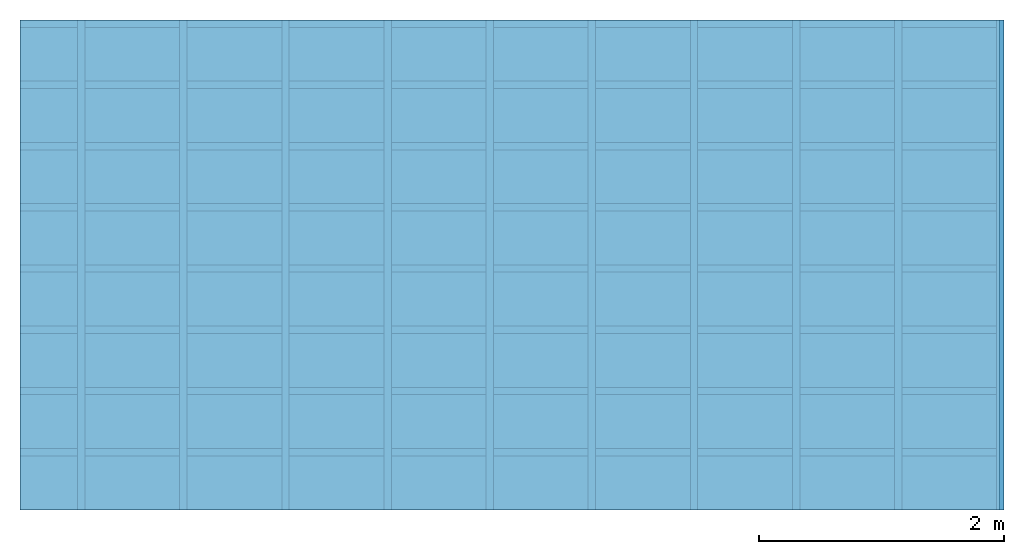
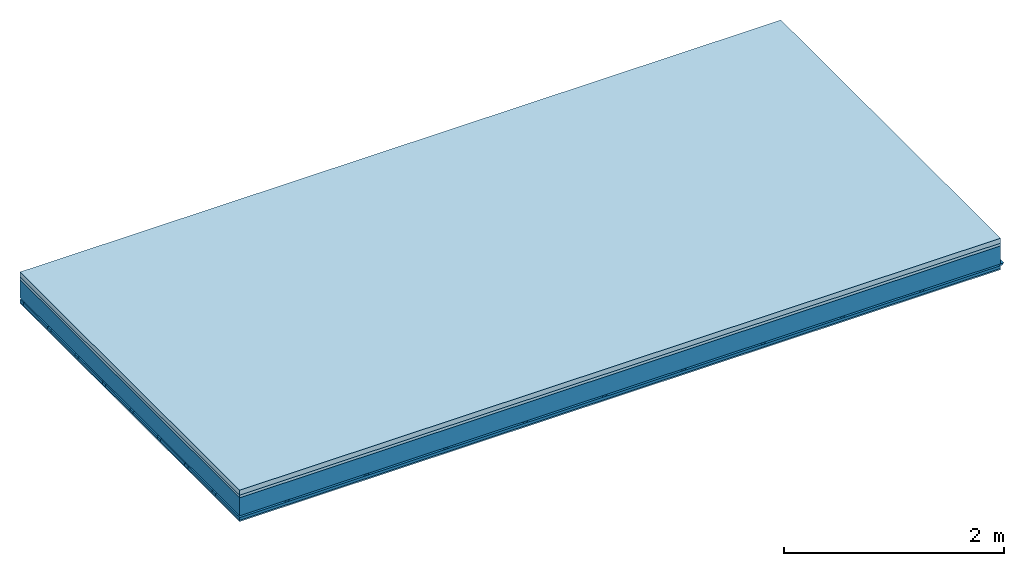
# One storey: 4 members, 3 plates, 1 element without a shape of its own.
"""IFC4 building model written with IfcOpenShell, lengths in metres."""

from ifc_helpers import new_model, si_unit, derived_unit, direction, frame, frame_2d, origin, origin_with_axes, place, context, project, spatial, polyline, rectangle, outline, extrude, material, layer, layer_set, type_object, element, aggregate, save


model = new_model("IFC4")

# Units and contexts
plan_context = context("Plan", 3, precision=1e-05, world=origin(), true_north=direction((0.0, 1.0)))
model_context = context("Model", 3, precision=1e-05, world=origin(), true_north=direction((0.0, 1.0)))
ifc_project = project(units=[si_unit("LENGTHUNIT", "METRE"), derived_unit("SOUNDPRESSUREUNIT", [(si_unit("PRESSUREUNIT", "PASCAL", prefix="MICRO"), 0)]), si_unit("ENERGYUNIT", "JOULE", prefix="MEGA"), si_unit("MASSUNIT", "GRAM", prefix="KILO"), derived_unit("THERMALTRANSMITTANCEUNIT", [(si_unit("POWERUNIT", "WATT"), 1), (si_unit("AREAUNIT", "SQUARE_METRE"), -1), (si_unit("THERMODYNAMICTEMPERATUREUNIT", "KELVIN"), -1)]), derived_unit("AREADENSITYUNIT", [(si_unit("MASSUNIT", "GRAM", prefix="KILO"), 1), (si_unit("AREAUNIT", "SQUARE_METRE"), -1)]), derived_unit("USERDEFINED", [(si_unit("ENERGYUNIT", "JOULE", prefix="MEGA"), 1), (si_unit("AREAUNIT", "SQUARE_METRE"), -1)])], contexts=[plan_context, model_context])

# Site, building, storey
site = spatial("IfcSite", under=ifc_project)
building_placement = place(None, origin())
building = spatial("IfcBuilding", under=site, at=building_placement)
storey_placement = place(building_placement, origin())
storey = spatial("IfcBuildingStorey", under=building, at=storey_placement)

# Slab, members, plates
ifc_material_1 = material(Category="04.005")
ifc_layer_1 = layer(ifc_material_1, 0.055, Name="On-material")
ifc_material_2 = material()
ifc_layer_2 = layer(ifc_material_2, 0.03, Name="Impact sound insulation")
ifc_layer_3 = layer(None, 0.2, Name="Supporting structure")
ifc_material_3 = material(Name="no composite action")
ifc_layer_4 = layer(ifc_material_3, 0.0, Name="Bond")
ifc_layer_5 = layer(None, 0.02, Name="Coupling")
ifc_layer_6 = layer(None, 0.03, Name="Battens / profiles")
ifc_material_4 = material(Category="03.007")
ifc_layer_7 = layer(ifc_material_4, 0.015, Name="Ceiling covering 1st layer")
ifc_material_5 = material(Name="Glued joints")
ifc_layer_8 = layer(ifc_material_5, 0.0, Name="Surface / treatment")
ifc_layer_set = layer_set([ifc_layer_1, ifc_layer_2, ifc_layer_3, ifc_layer_4, ifc_layer_5, ifc_layer_6, ifc_layer_7, ifc_layer_8])
slab_type = type_object("IfcSlabType", Name="A0864", PredefinedType="NOTDEFINED", material=ifc_layer_set)
slab_placement = place(None, frame((0.0, 0.0, 0.0), z_axis=(0.0, 0.0, -1.0), x_axis=(1.0, 0.0, 0.0)))
slab = element("IfcSlab", 1, at=slab_placement, inside=storey, type_object=slab_type, material=ifc_layer_set, Name="Slab #1")
ifc_material_6 = material()
member_1_placement = place(slab_placement, origin())
member_1 = element("IfcMember", 2, at=member_1_placement, material=ifc_material_6, Name="Supporting structure", context=plan_context, shape_type="SweptSolid", body=[
    extrude(rectangle(XDim=1.0, YDim=0.2, at=frame_2d((0.5, 0.1), x_axis=(1.0, 0.0))), frame((0.0, 4.0, 0.085), z_axis=(0.0, -1.0, 0.0), x_axis=(1.0, 0.0, 0.0)), (0.0, 0.0, 1.0), 4.0),
    extrude(rectangle(XDim=1.0, YDim=0.2, at=frame_2d((0.5, 0.1), x_axis=(1.0, 0.0))), frame((1.0, 4.0, 0.085), z_axis=(0.0, -1.0, 0.0), x_axis=(1.0, 0.0, 0.0)), (0.0, 0.0, 1.0), 4.0),
    extrude(rectangle(XDim=1.0, YDim=0.2, at=frame_2d((0.5, 0.1), x_axis=(1.0, 0.0))), frame((2.0, 4.0, 0.085), z_axis=(0.0, -1.0, 0.0), x_axis=(1.0, 0.0, 0.0)), (0.0, 0.0, 1.0), 4.0),
    extrude(rectangle(XDim=1.0, YDim=0.2, at=frame_2d((0.5, 0.1), x_axis=(1.0, 0.0))), frame((3.0, 4.0, 0.085), z_axis=(0.0, -1.0, 0.0), x_axis=(1.0, 0.0, 0.0)), (0.0, 0.0, 1.0), 4.0),
    extrude(rectangle(XDim=1.0, YDim=0.2, at=frame_2d((0.5, 0.1), x_axis=(1.0, 0.0))), frame((4.0, 4.0, 0.085), z_axis=(0.0, -1.0, 0.0), x_axis=(1.0, 0.0, 0.0)), (0.0, 0.0, 1.0), 4.0),
    extrude(rectangle(XDim=1.0, YDim=0.2, at=frame_2d((0.5, 0.1), x_axis=(1.0, 0.0))), frame((5.0, 4.0, 0.085), z_axis=(0.0, -1.0, 0.0), x_axis=(1.0, 0.0, 0.0)), (0.0, 0.0, 1.0), 4.0),
    extrude(rectangle(XDim=1.0, YDim=0.2, at=frame_2d((0.5, 0.1), x_axis=(1.0, 0.0))), frame((6.0, 4.0, 0.085), z_axis=(0.0, -1.0, 0.0), x_axis=(1.0, 0.0, 0.0)), (0.0, 0.0, 1.0), 4.0),
    extrude(rectangle(XDim=1.0, YDim=0.2, at=frame_2d((0.5, 0.1), x_axis=(1.0, 0.0))), frame((7.0, 4.0, 0.085), z_axis=(0.0, -1.0, 0.0), x_axis=(1.0, 0.0, 0.0)), (0.0, 0.0, 1.0), 4.0),
])
ifc_material_7 = material()
member_2_placement = place(slab_placement, origin())
member_2 = element("IfcMember", 3, at=member_2_placement, material=ifc_material_7, Name="Coupling", context=plan_context, shape_type="SweptSolid", body=[
    extrude(outline(polyline([(0.0, 0.0), (0.06, 0.0), (0.04, 0.02), (0.02, 0.02), (0.0, 0.0)])), frame((0.47, 4.0, 0.285), z_axis=(0.0, -1.0, 0.0), x_axis=(1.0, 0.0, 0.0)), (0.0, 0.0, 1.0), 4.0),
    extrude(outline(polyline([(0.0, 0.0), (0.06, 0.0), (0.04, 0.02), (0.02, 0.02), (0.0, 0.0)])), frame((1.304, 4.0, 0.285), z_axis=(0.0, -1.0, 0.0), x_axis=(1.0, 0.0, 0.0)), (0.0, 0.0, 1.0), 4.0),
    extrude(outline(polyline([(0.0, 0.0), (0.06, 0.0), (0.04, 0.02), (0.02, 0.02), (0.0, 0.0)])), frame((2.138, 4.0, 0.285), z_axis=(0.0, -1.0, 0.0), x_axis=(1.0, 0.0, 0.0)), (0.0, 0.0, 1.0), 4.0),
    extrude(outline(polyline([(0.0, 0.0), (0.06, 0.0), (0.04, 0.02), (0.02, 0.02), (0.0, 0.0)])), frame((2.972, 4.0, 0.285), z_axis=(0.0, -1.0, 0.0), x_axis=(1.0, 0.0, 0.0)), (0.0, 0.0, 1.0), 4.0),
    extrude(outline(polyline([(0.0, 0.0), (0.06, 0.0), (0.04, 0.02), (0.02, 0.02), (0.0, 0.0)])), frame((3.806, 4.0, 0.285), z_axis=(0.0, -1.0, 0.0), x_axis=(1.0, 0.0, 0.0)), (0.0, 0.0, 1.0), 4.0),
    extrude(outline(polyline([(0.0, 0.0), (0.06, 0.0), (0.04, 0.02), (0.02, 0.02), (0.0, 0.0)])), frame((4.64, 4.0, 0.285), z_axis=(0.0, -1.0, 0.0), x_axis=(1.0, 0.0, 0.0)), (0.0, 0.0, 1.0), 4.0),
    extrude(outline(polyline([(0.0, 0.0), (0.06, 0.0), (0.04, 0.02), (0.02, 0.02), (0.0, 0.0)])), frame((5.474, 4.0, 0.285), z_axis=(0.0, -1.0, 0.0), x_axis=(1.0, 0.0, 0.0)), (0.0, 0.0, 1.0), 4.0),
    extrude(outline(polyline([(0.0, 0.0), (0.06, 0.0), (0.04, 0.02), (0.02, 0.02), (0.0, 0.0)])), frame((6.308, 4.0, 0.285), z_axis=(0.0, -1.0, 0.0), x_axis=(1.0, 0.0, 0.0)), (0.0, 0.0, 1.0), 4.0),
    extrude(outline(polyline([(0.0, 0.0), (0.06, 0.0), (0.04, 0.02), (0.02, 0.02), (0.0, 0.0)])), frame((7.142, 4.0, 0.285), z_axis=(0.0, -1.0, 0.0), x_axis=(1.0, 0.0, 0.0)), (0.0, 0.0, 1.0), 4.0),
    extrude(outline(polyline([(0.0, 0.0), (0.06, 0.0), (0.04, 0.02), (0.02, 0.02), (0.0, 0.0)])), frame((7.976, 4.0, 0.285), z_axis=(0.0, -1.0, 0.0), x_axis=(1.0, 0.0, 0.0)), (0.0, 0.0, 1.0), 4.0),
])
ifc_material_8 = material()
member_3_placement = place(slab_placement, origin())
member_3 = element("IfcMember", 4, at=member_3_placement, material=ifc_material_8, Name="Battens / profiles", context=plan_context, shape_type="SweptSolid", body=[
    extrude(rectangle(XDim=0.06, YDim=0.03, at=frame_2d((0.03, 0.015), x_axis=(1.0, 0.0))), frame((0.0, 0.0, 0.305), z_axis=(1.0, 0.0, 0.0), x_axis=(0.0, 1.0, 0.0)), (0.0, 0.0, 1.0), 8.0),
    extrude(rectangle(XDim=0.06, YDim=0.03, at=frame_2d((0.03, 0.015), x_axis=(1.0, 0.0))), frame((0.0, 0.5, 0.305), z_axis=(1.0, 0.0, 0.0), x_axis=(0.0, 1.0, 0.0)), (0.0, 0.0, 1.0), 8.0),
    extrude(rectangle(XDim=0.06, YDim=0.03, at=frame_2d((0.03, 0.015), x_axis=(1.0, 0.0))), frame((0.0, 1.0, 0.305), z_axis=(1.0, 0.0, 0.0), x_axis=(0.0, 1.0, 0.0)), (0.0, 0.0, 1.0), 8.0),
    extrude(rectangle(XDim=0.06, YDim=0.03, at=frame_2d((0.03, 0.015), x_axis=(1.0, 0.0))), frame((0.0, 1.5, 0.305), z_axis=(1.0, 0.0, 0.0), x_axis=(0.0, 1.0, 0.0)), (0.0, 0.0, 1.0), 8.0),
    extrude(rectangle(XDim=0.06, YDim=0.03, at=frame_2d((0.03, 0.015), x_axis=(1.0, 0.0))), frame((0.0, 2.0, 0.305), z_axis=(1.0, 0.0, 0.0), x_axis=(0.0, 1.0, 0.0)), (0.0, 0.0, 1.0), 8.0),
    extrude(rectangle(XDim=0.06, YDim=0.03, at=frame_2d((0.03, 0.015), x_axis=(1.0, 0.0))), frame((0.0, 2.5, 0.305), z_axis=(1.0, 0.0, 0.0), x_axis=(0.0, 1.0, 0.0)), (0.0, 0.0, 1.0), 8.0),
    extrude(rectangle(XDim=0.06, YDim=0.03, at=frame_2d((0.03, 0.015), x_axis=(1.0, 0.0))), frame((0.0, 3.0, 0.305), z_axis=(1.0, 0.0, 0.0), x_axis=(0.0, 1.0, 0.0)), (0.0, 0.0, 1.0), 8.0),
    extrude(rectangle(XDim=0.06, YDim=0.03, at=frame_2d((0.03, 0.015), x_axis=(1.0, 0.0))), frame((0.0, 3.5, 0.305), z_axis=(1.0, 0.0, 0.0), x_axis=(0.0, 1.0, 0.0)), (0.0, 0.0, 1.0), 8.0),
])
ifc_material_9 = material()
member_4_placement = place(slab_placement, origin())
member_4 = element("IfcMember", 5, at=member_4_placement, material=ifc_material_9, Name="Cavity", context=plan_context, shape_type="SweptSolid", body=[
    extrude(rectangle(XDim=0.44, YDim=0.03, at=frame_2d((0.22, 0.015), x_axis=(1.0, 0.0))), frame((0.0, 0.06, 0.305), z_axis=(1.0, 0.0, 0.0), x_axis=(0.0, 1.0, 0.0)), (0.0, 0.0, 1.0), 8.0),
    extrude(rectangle(XDim=0.44, YDim=0.03, at=frame_2d((0.22, 0.015), x_axis=(1.0, 0.0))), frame((0.0, 0.56, 0.305), z_axis=(1.0, 0.0, 0.0), x_axis=(0.0, 1.0, 0.0)), (0.0, 0.0, 1.0), 8.0),
    extrude(rectangle(XDim=0.44, YDim=0.03, at=frame_2d((0.22, 0.015), x_axis=(1.0, 0.0))), frame((0.0, 1.06, 0.305), z_axis=(1.0, 0.0, 0.0), x_axis=(0.0, 1.0, 0.0)), (0.0, 0.0, 1.0), 8.0),
    extrude(rectangle(XDim=0.44, YDim=0.03, at=frame_2d((0.22, 0.015), x_axis=(1.0, 0.0))), frame((0.0, 1.56, 0.305), z_axis=(1.0, 0.0, 0.0), x_axis=(0.0, 1.0, 0.0)), (0.0, 0.0, 1.0), 8.0),
    extrude(rectangle(XDim=0.44, YDim=0.03, at=frame_2d((0.22, 0.015), x_axis=(1.0, 0.0))), frame((0.0, 2.06, 0.305), z_axis=(1.0, 0.0, 0.0), x_axis=(0.0, 1.0, 0.0)), (0.0, 0.0, 1.0), 8.0),
    extrude(rectangle(XDim=0.44, YDim=0.03, at=frame_2d((0.22, 0.015), x_axis=(1.0, 0.0))), frame((0.0, 2.56, 0.305), z_axis=(1.0, 0.0, 0.0), x_axis=(0.0, 1.0, 0.0)), (0.0, 0.0, 1.0), 8.0),
    extrude(rectangle(XDim=0.44, YDim=0.03, at=frame_2d((0.22, 0.015), x_axis=(1.0, 0.0))), frame((0.0, 3.06, 0.305), z_axis=(1.0, 0.0, 0.0), x_axis=(0.0, 1.0, 0.0)), (0.0, 0.0, 1.0), 8.0),
    extrude(rectangle(XDim=0.44, YDim=0.03, at=frame_2d((0.22, 0.015), x_axis=(1.0, 0.0))), frame((0.0, 3.56, 0.305), z_axis=(1.0, 0.0, 0.0), x_axis=(0.0, 1.0, 0.0)), (0.0, 0.0, 1.0), 8.0),
])
plate_1_placement = place(slab_placement, origin())
plate_1 = element("IfcPlate", 6, at=plate_1_placement, material=ifc_material_1, Name="On-material", context=plan_context, shape_type="SweptSolid", body=[
    extrude(rectangle(XDim=8.0, YDim=4.0, at=frame_2d((4.0, 2.0), x_axis=(1.0, 0.0))), origin_with_axes(), (0.0, 0.0, 1.0), 0.055),
])
plate_2_placement = place(slab_placement, origin())
plate_2 = element("IfcPlate", 7, at=plate_2_placement, material=ifc_material_2, Name="Impact sound insulation", context=plan_context, shape_type="SweptSolid", body=[
    extrude(rectangle(XDim=8.0, YDim=4.0, at=frame_2d((4.0, 2.0), x_axis=(1.0, 0.0))), frame((0.0, 0.0, 0.055), z_axis=(0.0, 0.0, 1.0), x_axis=(1.0, 0.0, 0.0)), (0.0, 0.0, 1.0), 0.03),
])
plate_3_placement = place(slab_placement, origin())
plate_3 = element("IfcPlate", 8, at=plate_3_placement, material=ifc_material_4, Name="Ceiling covering 1st layer", context=plan_context, shape_type="SweptSolid", body=[
    extrude(rectangle(XDim=8.0, YDim=4.0, at=frame_2d((4.0, 2.0), x_axis=(1.0, 0.0))), frame((0.0, 0.0, 0.335), z_axis=(0.0, 0.0, 1.0), x_axis=(1.0, 0.0, 0.0)), (0.0, 0.0, 1.0), 0.015),
])
aggregate(slab, [plate_1, plate_2, member_1, member_2, member_3, member_4, plate_3])

save(model, "model.ifc")
